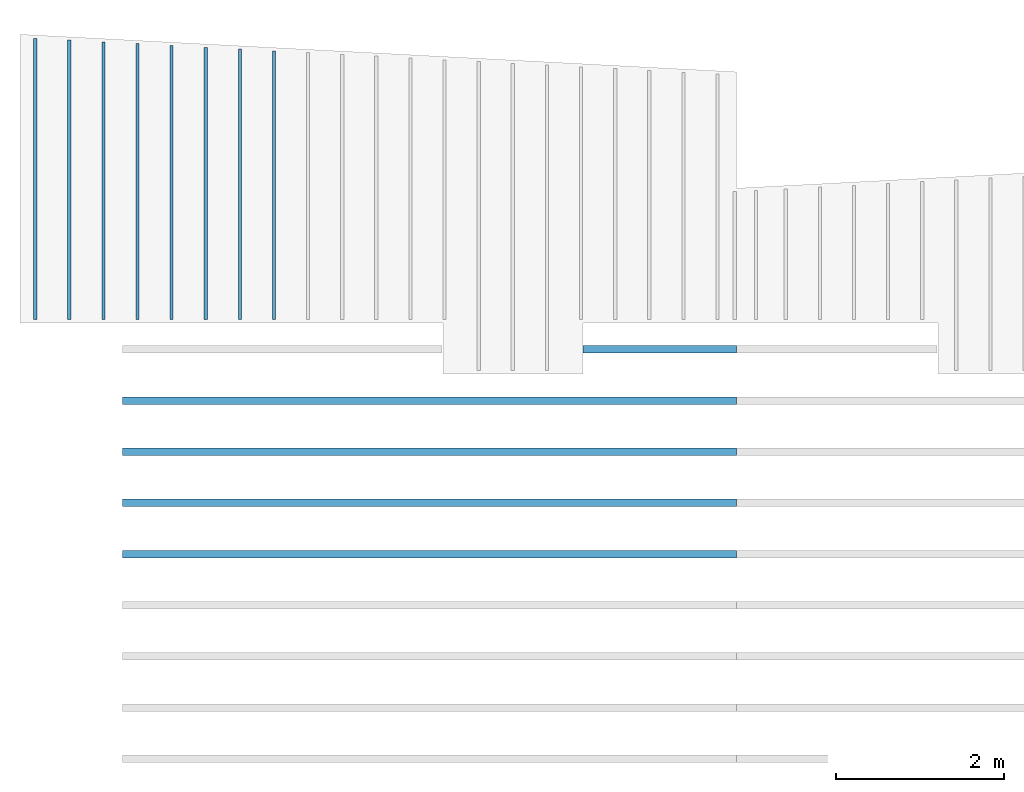
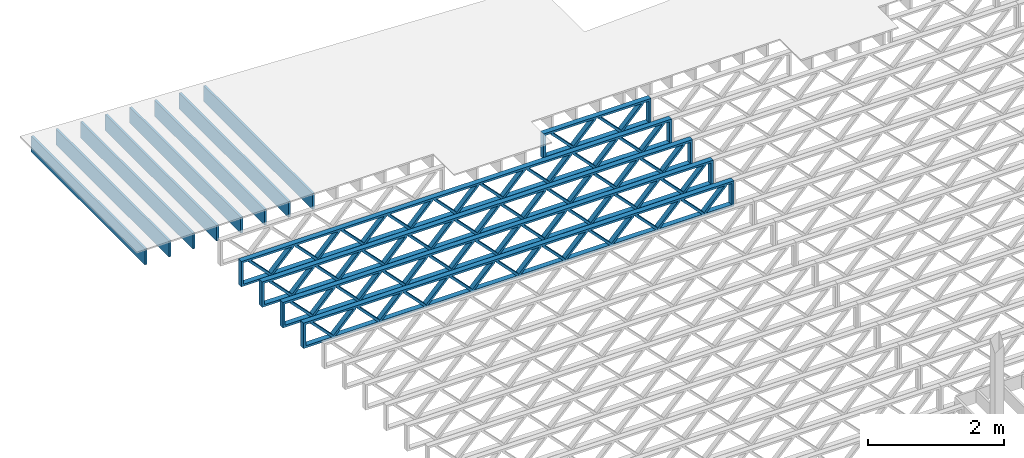
# One storey, part 3 of 13: 13 beams, 2 elements without a shape of their own.
"""IFC4 building model written with IfcOpenShell, lengths in feet."""

import ifcopenshell
import ifcopenshell.guid

model = None  # the IFC model being written
_history = None  # IfcOwnerHistory: only IFC2X3 demands one
_inside = {}  # id of a spatial element -> (the spatial element, [elements in it])
_under = {}  # id of a project, library or spatial element -> (it, [spatial elements below it])
_declared = {}  # id of a project -> (the project, [libraries it declares])
_typed = {}  # id of a type object -> (the type object, [elements of that type])
_made_of = {}  # id of a material, layer set ... -> (it, [elements and type objects made of it])


def new_model(schema):
    """Start an empty IFC model of exactly this schema.

    Asked for "IFC4X3", IfcOpenShell would pick the latest addendum, in which some entities
    have other attributes; the version numbers below select the first issue.
    IFC2X3 requires an IfcOwnerHistory on every rooted entity: one is made here for all.
    """
    global model, _history
    if schema == "IFC4X3":
        model = ifcopenshell.file(schema_version=(4, 3, 0, 0))
    else:
        model = ifcopenshell.file(schema=schema)
    _inside.clear()
    _under.clear()
    _declared.clear()
    _typed.clear()
    _made_of.clear()
    _history = None
    if model.schema == "IFC2X3":
        org = make("IfcOrganization", Name="unknown")
        user = make(
            "IfcPersonAndOrganization",
            ThePerson=make("IfcPerson", FamilyName="unknown"),
            TheOrganization=org,
        )
        app = make(
            "IfcApplication",
            ApplicationDeveloper=org,
            Version="unknown",
            ApplicationFullName="unknown",
            ApplicationIdentifier="unknown",
        )
        _history = make(
            "IfcOwnerHistory",
            OwningUser=user,
            OwningApplication=app,
            ChangeAction="ADDED",
            CreationDate=0,
        )
    return model


def make(cls, **values):
    """One entity of the class cls with the attributes given. An attribute that is None is left unset."""
    return model.create_entity(
        cls, **{name: value for name, value in values.items() if value is not None}
    )


def entity(cls, *values):
    """Any entity or typed value of the class cls, its attributes in the order of the schema. None: left unset."""
    e = model.create_entity(cls)
    for i, value in enumerate(values):
        if value is not None:
            e[i] = value
    return e


def rooted(cls, **values):
    """An entity with a GlobalId (a new one), such as an element, a storey or a relation."""
    return make(cls, GlobalId=ifcopenshell.guid.new(), OwnerHistory=_history, **values)


def si_unit(unit_type, name, prefix=None):
    """IfcSIUnit, for example si_unit("LENGTHUNIT", "METRE", prefix="MILLI")."""
    return make("IfcSIUnit", UnitType=unit_type, Prefix=prefix, Name=name)


def converted_unit(unit_type, name, factor, base, dimensions=None, offset=None):
    """IfcConversionBasedUnit, such as the inch: factor (a typed value) times the base unit."""
    return make(
        "IfcConversionBasedUnit"
        if offset is None
        else "IfcConversionBasedUnitWithOffset",
        ConversionOffset=offset,
        Dimensions=None
        if dimensions is None
        else entity("IfcDimensionalExponents", *dimensions),
        UnitType=unit_type,
        Name=name,
        ConversionFactor=make(
            "IfcMeasureWithUnit", ValueComponent=factor, UnitComponent=base
        ),
    )


def derived_unit(unit_type, elements):
    """IfcDerivedUnit: a product of units, each with its exponent."""
    return make(
        "IfcDerivedUnit",
        Elements=[
            make("IfcDerivedUnitElement", Unit=unit, Exponent=power)
            for unit, power in elements
        ],
        UnitType=unit_type,
    )


def assignment(units):
    """IfcUnitAssignment: the units of a project."""
    return None if units is None else make("IfcUnitAssignment", Units=units)


def point(xyz):
    """IfcCartesianPoint."""
    return None if xyz is None else make("IfcCartesianPoint", Coordinates=xyz)


def direction(xyz):
    """IfcDirection."""
    return None if xyz is None else make("IfcDirection", DirectionRatios=xyz)


def frame(location, z_axis=None, x_axis=None):
    """IfcAxis2Placement3D, a coordinate frame: its origin and axes. An axis left out is left unset."""
    return make(
        "IfcAxis2Placement3D",
        Location=point(location),
        Axis=direction(z_axis),
        RefDirection=direction(x_axis),
    )


def frame_2d(location, x_axis=None):
    """IfcAxis2Placement2D, a coordinate frame in the plane: its origin and x axis."""
    return make(
        "IfcAxis2Placement2D", Location=point(location), RefDirection=direction(x_axis)
    )


def origin():
    """The frame at (0, 0, 0) with its axes left unset."""
    return frame((0.0, 0.0, 0.0))


def origin_2d_with_axis():
    """The frame at (0, 0) in the plane with the x axis (1, 0) written out."""
    return frame_2d((0.0, 0.0), x_axis=(1.0, 0.0))


def place(relative_to, where):
    """IfcLocalPlacement: puts the frame where relative to a parent placement (None: the world)."""
    return make(
        "IfcLocalPlacement", PlacementRelTo=relative_to, RelativePlacement=where
    )


def context(
    kind, dimensions, precision=None, world=None, true_north=None, identifier=None
):
    """IfcGeometricRepresentationContext, for example the 3D "Model" context."""
    return make(
        "IfcGeometricRepresentationContext",
        ContextIdentifier=identifier,
        ContextType=kind,
        CoordinateSpaceDimension=dimensions,
        Precision=precision,
        WorldCoordinateSystem=world,
        TrueNorth=true_north,
    )


def subcontext(parent, identifier, kind, view, scale=None):
    """IfcGeometricRepresentationSubContext, for example "Body" below "Model"."""
    return make(
        "IfcGeometricRepresentationSubContext",
        ContextIdentifier=identifier,
        ContextType=kind,
        ParentContext=parent,
        TargetScale=scale,
        TargetView=view,
    )


def project(units=None, contexts=None):
    """IfcProject with its units and contexts."""
    return rooted(
        "IfcProject",
        Name="project",
        RepresentationContexts=contexts,
        UnitsInContext=assignment(units),
    )


def spatial(cls, under=None, at=None, **own):
    """A site, building, storey or space (cls), placed at a placement, below another one or the project."""
    s = rooted(cls, ObjectPlacement=at, **own)
    if under is not None:
        _under.setdefault(under.id(), (under, []))[1].append(s)
    return s


def profile(cls, at=None, kind="AREA", **sizes):
    """A parametric profile (cls). Its sizes go by their IFC names, for example OverallWidth=200.0."""
    return make(cls, ProfileType=kind, Position=at, **sizes)


def rectangle(**sizes):
    """IfcRectangleProfileDef."""
    return profile("IfcRectangleProfileDef", **sizes)


def extrude(swept, where, along, depth):
    """IfcExtrudedAreaSolid: the profile swept, set in the frame where, extruded along a direction by depth."""
    return make(
        "IfcExtrudedAreaSolid",
        SweptArea=swept,
        Position=where,
        ExtrudedDirection=direction(along),
        Depth=depth,
    )


def shape(context_of_items, identifier, shape_type, items):
    """IfcShapeRepresentation: the items that make up one representation, for example the "Body"."""
    return make(
        "IfcShapeRepresentation",
        ContextOfItems=context_of_items,
        RepresentationIdentifier=identifier,
        RepresentationType=shape_type,
        Items=items,
    )


def source(mapping_origin, context_of_items, identifier, shape_type, items):
    """IfcRepresentationMap: a shape defined once, which mapped items show again and again."""
    return make(
        "IfcRepresentationMap",
        MappingOrigin=mapping_origin,
        MappedRepresentation=shape(context_of_items, identifier, shape_type, items),
    )


def transform(
    local_origin,
    x_axis=None,
    y_axis=None,
    z_axis=None,
    scale=None,
    scale2=None,
    scale3=None,
    uniform=True,
):
    """IfcCartesianTransformationOperator3D, or its non-uniform kind. x_axis, y_axis, z_axis: its Axis1, 2, 3."""
    if uniform:
        return make(
            "IfcCartesianTransformationOperator3D",
            Axis1=direction(x_axis),
            Axis2=direction(y_axis),
            LocalOrigin=point(local_origin),
            Scale=scale,
            Axis3=direction(z_axis),
        )
    return make(
        "IfcCartesianTransformationOperator3DnonUniform",
        Axis1=direction(x_axis),
        Axis2=direction(y_axis),
        LocalOrigin=point(local_origin),
        Scale=scale,
        Axis3=direction(z_axis),
        Scale2=scale2,
        Scale3=scale3,
    )


def mapped(mapping_source, mapping_target):
    """IfcMappedItem: shows the shape of a source again, moved by a transform."""
    return make(
        "IfcMappedItem", MappingSource=mapping_source, MappingTarget=mapping_target
    )


def material(Name=None, Category=None):
    """IfcMaterial."""
    return make("IfcMaterial", Name=Name, Category=Category)


def material_profile(
    of_material, cross_section, Name=None, Category=None, Priority=None
):
    """IfcMaterialProfile: a cross section and its material."""
    return make(
        "IfcMaterialProfile",
        Name=Name,
        Material=of_material,
        Profile=cross_section,
        Priority=Priority,
        Category=Category,
    )


def profile_set(profiles, Name=None, composite=None):
    """IfcMaterialProfileSet."""
    return make(
        "IfcMaterialProfileSet",
        Name=Name,
        MaterialProfiles=profiles,
        CompositeProfile=composite,
    )


def profile_usage(for_profile_set, cardinal=None, extent=None):
    """IfcMaterialProfileSetUsage: how a profile set lies along its element."""
    return make(
        "IfcMaterialProfileSetUsage",
        ForProfileSet=for_profile_set,
        CardinalPoint=cardinal,
        ReferenceExtent=extent,
    )


def made_of(thing, what):
    """Note that an element or type object is made of a material, layer set ...; save() writes the relation."""
    if what is not None:
        _made_of.setdefault(what.id(), (what, []))[1].append(thing)
    return thing


def type_object(cls, material=None, **own):
    """A type object (cls), such as IfcWallType, which elements share."""
    return made_of(rooted(cls, **own), material)


def type_shapes(of_type, sources):
    """Give a type object the sources (RepresentationMaps) that its elements show as mapped items."""
    of_type.RepresentationMaps = sources


def element(
    cls,
    number,
    at=None,
    inside=None,
    cuts=None,
    type_object=None,
    material=None,
    context=None,
    identifier="Body",
    shape_type=None,
    held_by="IfcProductDefinitionShape",
    body=None,
    shapes=None,
    **own,
):
    """One element of the class cls, such as IfcWall. Its Tag is "e" and its number.

    at: its placement. inside: the storey or other place that contains it. cuts: it is an
    opening in that element (IfcRelVoidsElement). A single representation is given by context,
    identifier, shape_type and body (its items); several are given by shapes. held_by: the class
    of the entity that holds the representations. save() writes the other relations.
    """
    e = rooted(cls, Tag="e%d" % number, ObjectPlacement=at, **own)
    if body is not None:
        shapes = [shape(context, identifier, shape_type, body)]
    if shapes is not None:
        e.Representation = make(held_by, Representations=shapes)
    if inside is not None:
        _inside.setdefault(inside.id(), (inside, []))[1].append(e)
    if cuts is not None:
        rooted(
            "IfcRelVoidsElement", RelatingBuildingElement=cuts, RelatedOpeningElement=e
        )
    if type_object is not None:
        _typed.setdefault(type_object.id(), (type_object, []))[1].append(e)
    return made_of(e, material)


def aggregate(whole, parts):
    """IfcRelAggregates: a whole, such as a stair, and the parts it consists of."""
    return rooted("IfcRelAggregates", RelatingObject=whole, RelatedObjects=parts)


def save(model, path):
    """Write the relations noted so far, then the file.

    IfcRelAggregates (storeys below a building ...), IfcRelContainedInSpatialStructure (elements
    in a storey), IfcRelDefinesByType, IfcRelAssociatesMaterial and IfcRelDeclares: one each for
    every whole, place, type object, material and project.
    """
    for whole, parts in _under.values():
        aggregate(whole, parts)
    for where, things in _inside.values():
        rooted(
            "IfcRelContainedInSpatialStructure",
            RelatedElements=things,
            RelatingStructure=where,
        )
    for kind, things in _typed.values():
        rooted("IfcRelDefinesByType", RelatedObjects=things, RelatingType=kind)
    for what, things in _made_of.values():
        rooted("IfcRelAssociatesMaterial", RelatedObjects=things, RelatingMaterial=what)
    for by, libraries in _declared.values():
        rooted("IfcRelDeclares", RelatingContext=by, RelatedDefinitions=libraries)
    model.write(path)


model = new_model("IFC4")

# Units and contexts
model_context_1 = context("Model", 3, precision=0.0001, world=origin(), true_north=direction((6.12303176911189e-17, 1.0)))
model_context_2 = context("Model", 3, precision=0.0001, world=origin(), true_north=direction((6.12303176911189e-17, 1.0)))
body_context = subcontext(model_context_2, "Body", "Model", "MODEL_VIEW")
ifc_project = project(units=[converted_unit("LENGTHUNIT", "FOOT", entity("IfcRatioMeasure", 0.3048), si_unit("LENGTHUNIT", "METRE"), dimensions=[1, 0, 0, 0, 0, 0, 0]), converted_unit("AREAUNIT", "SQUARE FOOT", entity("IfcRatioMeasure", 0.09290304), si_unit("AREAUNIT", "SQUARE_METRE"), dimensions=[2, 0, 0, 0, 0, 0, 0]), converted_unit("VOLUMEUNIT", "CUBIC FOOT", entity("IfcRatioMeasure", 0.028316846592), si_unit("VOLUMEUNIT", "CUBIC_METRE"), dimensions=[3, 0, 0, 0, 0, 0, 0]), converted_unit("PLANEANGLEUNIT", "DEGREE", entity("IfcRatioMeasure", 0.0174532925199433), si_unit("PLANEANGLEUNIT", "RADIAN"), dimensions=[0, 0, 0, 0, 0, 0, 0]), si_unit("MASSUNIT", "GRAM", prefix="KILO"), derived_unit("MASSDENSITYUNIT", [(si_unit("MASSUNIT", "GRAM", prefix="KILO"), 1), (si_unit("LENGTHUNIT", "METRE"), -3)]), derived_unit("MOMENTOFINERTIAUNIT", [(si_unit("LENGTHUNIT", "METRE"), 4)]), si_unit("TIMEUNIT", "SECOND"), si_unit("FREQUENCYUNIT", "HERTZ"), si_unit("THERMODYNAMICTEMPERATUREUNIT", "DEGREE_CELSIUS"), derived_unit("THERMALTRANSMITTANCEUNIT", [(si_unit("MASSUNIT", "GRAM", prefix="KILO"), 1), (si_unit("THERMODYNAMICTEMPERATUREUNIT", "KELVIN"), -1), (si_unit("TIMEUNIT", "SECOND"), -3)]), derived_unit("VOLUMETRICFLOWRATEUNIT", [(si_unit("LENGTHUNIT", "METRE"), 3), (si_unit("TIMEUNIT", "SECOND"), -1)]), si_unit("ELECTRICCURRENTUNIT", "AMPERE"), si_unit("ELECTRICVOLTAGEUNIT", "VOLT"), si_unit("POWERUNIT", "WATT"), si_unit("FORCEUNIT", "NEWTON"), si_unit("ILLUMINANCEUNIT", "LUX"), si_unit("LUMINOUSFLUXUNIT", "LUMEN"), si_unit("LUMINOUSINTENSITYUNIT", "CANDELA"), derived_unit("USERDEFINED", [(si_unit("MASSUNIT", "GRAM", prefix="KILO"), -1), (si_unit("LENGTHUNIT", "METRE"), -2), (si_unit("TIMEUNIT", "SECOND"), 3), (si_unit("LUMINOUSFLUXUNIT", "LUMEN"), 1)]), derived_unit("LINEARVELOCITYUNIT", [(si_unit("LENGTHUNIT", "METRE"), 1), (si_unit("TIMEUNIT", "SECOND"), -1)]), si_unit("PRESSUREUNIT", "PASCAL"), derived_unit("USERDEFINED", [(si_unit("LENGTHUNIT", "METRE"), -2), (si_unit("MASSUNIT", "GRAM", prefix="KILO"), 1), (si_unit("TIMEUNIT", "SECOND"), -2)]), derived_unit("LINEARFORCEUNIT", [(si_unit("MASSUNIT", "GRAM", prefix="KILO"), 1), (si_unit("LENGTHUNIT", "METRE"), 1), (si_unit("TIMEUNIT", "SECOND"), -2), (si_unit("LENGTHUNIT", "METRE"), -1)]), derived_unit("PLANARFORCEUNIT", [(si_unit("MASSUNIT", "GRAM", prefix="KILO"), 1), (si_unit("LENGTHUNIT", "METRE"), 1), (si_unit("TIMEUNIT", "SECOND"), -2), (si_unit("LENGTHUNIT", "METRE"), -2)])], contexts=[model_context_1])

# Site, building, storey
site_placement = place(None, origin())
site = spatial("IfcSite", under=ifc_project, at=site_placement, CompositionType="ELEMENT")
building_placement = place(site_placement, origin())
building = spatial("IfcBuilding", under=site, at=building_placement, CompositionType="ELEMENT")
storey_placement = place(building_placement, frame((0.0, 0.0, 21.46875)))
storey = spatial("IfcBuildingStorey", under=building, at=storey_placement, Name="3RD FLOOR", CompositionType="ELEMENT", Elevation=21.46875)

# Assembly, beams
assembly_1_placement = place(storey_placement, origin())
assembly_1 = element("IfcElementAssembly", 1, at=assembly_1_placement, inside=storey, Name="Structural Beam System:Structural Framing System", ObjectType="Structural Beam System:Structural Framing System", AssemblyPlace="NOTDEFINED", PredefinedType="BEAM_GRID")
ifc_material_1 = material(Category="Materials")
ifc_material_profile_1 = material_profile(ifc_material_1, rectangle(XDim=0.9375, YDim=0.125000000000011, at=origin_2d_with_axis()))
ifc_profile_set_1 = profile_set([ifc_material_profile_1])
ifc_profile_usage_1 = profile_usage(ifc_profile_set_1, cardinal=8)
beam_type_1 = type_object("IfcBeamType", PredefinedType="BEAM", material=ifc_profile_set_1)
shared_shape_1 = source(origin(), body_context, "Body", "SweptSolid", [
    extrude(rectangle(XDim=0.9375, YDim=0.125000000000011, at=origin_2d_with_axis()), frame((-5.2509000693218, 0.0, 0.0), z_axis=(1.0, 0.0, 0.0), x_axis=(0.0, 0.0, -1.0)), (0.0, 0.0, 1.0), 10.5018001386436),
])
type_shapes(beam_type_1, [shared_shape_1])
beam_1_placement = place(assembly_1_placement, frame((-259.810956052701, 964.279501138386, -0.729166666666714), z_axis=(0.0, 0.0, 1.0), x_axis=(0.0, 1.0, 0.0)))
beam_1 = element("IfcBeam", 2, at=beam_1_placement, type_object=beam_type_1, material=ifc_profile_usage_1, PredefinedType="BEAM", context=body_context, shape_type="MappedRepresentation", body=[
    mapped(shared_shape_1, transform((0.0, 0.0, 0.0), scale=1.0)),
])
ifc_profile_usage_2 = profile_usage(ifc_profile_set_1, cardinal=8)
beam_type_2 = type_object("IfcBeamType", PredefinedType="BEAM", material=ifc_profile_set_1)
shared_shape_2 = source(origin(), body_context, "Body", "SweptSolid", [
    extrude(rectangle(XDim=0.9375, YDim=0.125000000000011, at=origin_2d_with_axis()), frame((-5.32077710836586, 0.0, 0.0), z_axis=(1.0, 0.0, 0.0), x_axis=(0.0, 0.0, -1.0)), (0.0, 0.0, 1.0), 10.6415542167317),
])
type_shapes(beam_type_2, [shared_shape_2])
beam_2_placement = place(assembly_1_placement, frame((-262.477622719368, 964.34937817743, -0.729166666666714), z_axis=(0.0, 0.0, 1.0), x_axis=(0.0, 1.0, 0.0)))
beam_2 = element("IfcBeam", 3, at=beam_2_placement, type_object=beam_type_2, material=ifc_profile_usage_2, PredefinedType="BEAM", context=body_context, shape_type="MappedRepresentation", body=[
    mapped(shared_shape_2, transform((0.0, 0.0, 0.0), scale=1.0)),
])
ifc_profile_usage_3 = profile_usage(ifc_profile_set_1, cardinal=8)
beam_type_3 = type_object("IfcBeamType", PredefinedType="BEAM", material=ifc_profile_set_1)
shared_shape_3 = source(origin(), body_context, "Body", "SweptSolid", [
    extrude(rectangle(XDim=0.9375, YDim=0.125000000000011, at=origin_2d_with_axis()), frame((-5.39065414740986, 0.0, 0.0), z_axis=(1.0, 0.0, 0.0), x_axis=(0.0, 0.0, -1.0)), (0.0, 0.0, 1.0), 10.7813082948197),
])
type_shapes(beam_type_3, [shared_shape_3])
beam_3_placement = place(assembly_1_placement, frame((-265.144289386034, 964.419255216474, -0.729166666666714), z_axis=(0.0, 0.0, 1.0), x_axis=(0.0, 1.0, 0.0)))
beam_3 = element("IfcBeam", 4, at=beam_3_placement, type_object=beam_type_3, material=ifc_profile_usage_3, PredefinedType="BEAM", context=body_context, shape_type="MappedRepresentation", body=[
    mapped(shared_shape_3, transform((0.0, 0.0, 0.0), scale=1.0)),
])
ifc_profile_usage_4 = profile_usage(ifc_profile_set_1, cardinal=8)
beam_type_4 = type_object("IfcBeamType", PredefinedType="BEAM", material=ifc_profile_set_1)
shared_shape_4 = source(origin(), body_context, "Body", "SweptSolid", [
    extrude(rectangle(XDim=0.9375, YDim=0.125000000000011, at=origin_2d_with_axis()), frame((-5.49546970597595, 0.0, 0.0), z_axis=(1.0, 0.0, 0.0), x_axis=(0.0, 0.0, -1.0)), (0.0, 0.0, 1.0), 10.9909394119519),
])
type_shapes(beam_type_4, [shared_shape_4])
beam_4_placement = place(assembly_1_placement, frame((-269.144289386034, 964.52407077504, -0.729166666666714), z_axis=(0.0, 0.0, 1.0), x_axis=(0.0, 1.0, 0.0)))
beam_4 = element("IfcBeam", 5, at=beam_4_placement, type_object=beam_type_4, material=ifc_profile_usage_4, PredefinedType="BEAM", context=body_context, shape_type="MappedRepresentation", body=[
    mapped(shared_shape_4, transform((0.0, 0.0, 0.0), scale=1.0)),
])
ifc_profile_usage_5 = profile_usage(ifc_profile_set_1, cardinal=8)
beam_type_5 = type_object("IfcBeamType", PredefinedType="BEAM", material=ifc_profile_set_1)
shared_shape_5 = source(origin(), body_context, "Body", "SweptSolid", [
    extrude(rectangle(XDim=0.9375, YDim=0.125000000000011, at=origin_2d_with_axis()), frame((-5.46053118645392, 0.0, 0.0), z_axis=(1.0, 0.0, 0.0), x_axis=(0.0, 0.0, -1.0)), (0.0, 0.0, 1.0), 10.9210623729078),
])
type_shapes(beam_type_5, [shared_shape_5])
beam_5_placement = place(assembly_1_placement, frame((-267.810956052701, 964.489132255518, -0.729166666666714), z_axis=(0.0, 0.0, 1.0), x_axis=(0.0, 1.0, 0.0)))
beam_5 = element("IfcBeam", 6, at=beam_5_placement, type_object=beam_type_5, material=ifc_profile_usage_5, PredefinedType="BEAM", context=body_context, shape_type="MappedRepresentation", body=[
    mapped(shared_shape_5, transform((0.0, 0.0, 0.0), scale=1.0)),
])
ifc_profile_usage_6 = profile_usage(ifc_profile_set_1, cardinal=8)
beam_type_6 = type_object("IfcBeamType", PredefinedType="BEAM", material=ifc_profile_set_1)
shared_shape_6 = source(origin(), body_context, "Body", "SweptSolid", [
    extrude(rectangle(XDim=0.9375, YDim=0.125000000000011, at=origin_2d_with_axis()), frame((-5.42559266693189, 0.0, 0.0), z_axis=(1.0, 0.0, 0.0), x_axis=(0.0, 0.0, -1.0)), (0.0, 0.0, 1.0), 10.8511853338638),
])
type_shapes(beam_type_6, [shared_shape_6])
beam_6_placement = place(assembly_1_placement, frame((-266.477622719368, 964.454193735996, -0.729166666666714), z_axis=(0.0, 0.0, 1.0), x_axis=(0.0, 1.0, 0.0)))
beam_6 = element("IfcBeam", 7, at=beam_6_placement, type_object=beam_type_6, material=ifc_profile_usage_6, PredefinedType="BEAM", context=body_context, shape_type="MappedRepresentation", body=[
    mapped(shared_shape_6, transform((0.0, 0.0, 0.0), scale=1.0)),
])
ifc_profile_usage_7 = profile_usage(ifc_profile_set_1, cardinal=8)
beam_type_7 = type_object("IfcBeamType", PredefinedType="BEAM", material=ifc_profile_set_1)
shared_shape_7 = source(origin(), body_context, "Body", "SweptSolid", [
    extrude(rectangle(XDim=0.9375, YDim=0.125000000000011, at=origin_2d_with_axis()), frame((-5.35571562788789, 0.0, 0.0), z_axis=(1.0, 0.0, 0.0), x_axis=(0.0, 0.0, -1.0)), (0.0, 0.0, 1.0), 10.7114312557758),
])
type_shapes(beam_type_7, [shared_shape_7])
beam_7_placement = place(assembly_1_placement, frame((-263.810956052701, 964.384316696952, -0.729166666666714), z_axis=(0.0, 0.0, 1.0), x_axis=(0.0, 1.0, 0.0)))
beam_7 = element("IfcBeam", 8, at=beam_7_placement, type_object=beam_type_7, material=ifc_profile_usage_7, PredefinedType="BEAM", context=body_context, shape_type="MappedRepresentation", body=[
    mapped(shared_shape_7, transform((0.0, 0.0, 0.0), scale=1.0)),
])
ifc_profile_usage_8 = profile_usage(ifc_profile_set_1, cardinal=8)
beam_type_8 = type_object("IfcBeamType", PredefinedType="BEAM", material=ifc_profile_set_1)
shared_shape_8 = source(origin(), body_context, "Body", "SweptSolid", [
    extrude(rectangle(XDim=0.9375, YDim=0.125000000000011, at=origin_2d_with_axis()), frame((-5.28583858884383, 0.0, 0.0), z_axis=(1.0, 0.0, 0.0), x_axis=(0.0, 0.0, -1.0)), (0.0, 0.0, 1.0), 10.5716771776877),
])
type_shapes(beam_type_8, [shared_shape_8])
beam_8_placement = place(assembly_1_placement, frame((-261.144289386034, 964.314439657908, -0.729166666666714), z_axis=(0.0, 0.0, 1.0), x_axis=(0.0, 1.0, 0.0)))
beam_8 = element("IfcBeam", 9, at=beam_8_placement, type_object=beam_type_8, material=ifc_profile_usage_8, PredefinedType="BEAM", context=body_context, shape_type="MappedRepresentation", body=[
    mapped(shared_shape_8, transform((0.0, 0.0, 0.0), scale=1.0)),
])
aggregate(assembly_1, [beam_1, beam_2, beam_3, beam_4, beam_5, beam_6, beam_7, beam_8])

assembly_2_placement = place(storey_placement, origin())
assembly_2 = element("IfcElementAssembly", 10, at=assembly_2_placement, inside=storey, Name="Structural Beam System:Structural Framing System", ObjectType="Structural Beam System:Structural Framing System", AssemblyPlace="NOTDEFINED", PredefinedType="BEAM_GRID")
ifc_material_2 = material(Name="WOOD TRUSS", Category="Materials")
ifc_material_profile_2 = material_profile(ifc_material_2, rectangle(XDim=1.73473973950632, YDim=0.125, at=frame_2d((-1.11022302462516e-16, 8.32667268468867e-17), x_axis=(1.0, 0.0))))
ifc_material_profile_3 = material_profile(ifc_material_2, rectangle(XDim=1.73473973950633, YDim=0.125, at=frame_2d((-1.11022302462516e-16, 8.32667268468867e-17), x_axis=(1.0, 0.0))))
ifc_material_profile_4 = material_profile(ifc_material_2, rectangle(XDim=1.73473973950632, YDim=0.125, at=frame_2d((-5.55111512312578e-17, 1.38777878078145e-16), x_axis=(1.0, 0.0))))
ifc_material_profile_5 = material_profile(ifc_material_2, rectangle(XDim=1.73473973950633, YDim=0.125, at=frame_2d((-1.11022302462516e-16, 8.32667268468867e-17), x_axis=(1.0, 0.0))))
ifc_material_profile_6 = material_profile(ifc_material_2, rectangle(XDim=1.73473973950632, YDim=0.125, at=frame_2d((-1.11022302462516e-16, 8.32667268468867e-17), x_axis=(1.0, 0.0))))
ifc_material_profile_7 = material_profile(ifc_material_2, rectangle(XDim=1.73473973950633, YDim=0.125, at=frame_2d((-2.77555756156289e-16, 3.05311331771918e-16), x_axis=(1.0, 0.0))))
ifc_material_profile_8 = material_profile(ifc_material_2, rectangle(XDim=1.73473973950632, YDim=0.124999999999999, at=frame_2d((-3.88578058618805e-16, -2.4980018054066e-16), x_axis=(1.0, 0.0))))
ifc_material_profile_9 = material_profile(ifc_material_2, rectangle(XDim=1.73473973950633, YDim=0.125, at=frame_2d((2.77555756156289e-16, -3.05311331771918e-16), x_axis=(1.0, 0.0))))
ifc_material_profile_10 = material_profile(ifc_material_2, rectangle(XDim=1.73473973950632, YDim=0.124999999999999, at=frame_2d((-1.11022302462516e-16, 8.32667268468867e-17), x_axis=(1.0, 0.0))))
ifc_material_profile_11 = material_profile(ifc_material_2, rectangle(XDim=1.73473973950633, YDim=0.125, at=origin_2d_with_axis()))
ifc_material_profile_12 = material_profile(ifc_material_2, rectangle(XDim=0.124999999999982, YDim=0.291666666666668, at=origin_2d_with_axis()))
ifc_material_profile_13 = material_profile(ifc_material_2, rectangle(XDim=0.124999999999932, YDim=0.291666666666664, at=origin_2d_with_axis()))
ifc_material_profile_14 = material_profile(ifc_material_2, rectangle(XDim=1.25000000000002, YDim=0.29166666666667, at=origin_2d_with_axis()))
ifc_material_profile_15 = material_profile(ifc_material_2, rectangle(XDim=1.25000000000004, YDim=0.291666666666667, at=origin_2d_with_axis()))
ifc_profile_set_2 = profile_set([ifc_material_profile_2, ifc_material_profile_3, ifc_material_profile_4, ifc_material_profile_5, ifc_material_profile_6, ifc_material_profile_7, ifc_material_profile_8, ifc_material_profile_9, ifc_material_profile_10, ifc_material_profile_11, ifc_material_profile_12, ifc_material_profile_13, ifc_material_profile_14, ifc_material_profile_15])
ifc_profile_usage_9 = profile_usage(ifc_profile_set_2, cardinal=8)
beam_type_9 = type_object("IfcBeamType", PredefinedType="BEAM", material=ifc_profile_set_2)
shared_shape_9 = source(origin(), body_context, "Body", "SweptSolid", [
    extrude(rectangle(XDim=1.73473973950632, YDim=0.124999999999999, at=frame_2d((5.55111512312578e-16, 7.21644966006352e-16), x_axis=(1.0, 0.0))), frame((8.37514585578398, -0.145833333333334, 0.0), z_axis=(0.0, 1.0, 0.0), x_axis=(0.693383046997606, 0.0, 0.720569184836762)), (0.0, 0.0, 1.0), 0.291666666666667),
    extrude(rectangle(XDim=1.73473973950633, YDim=0.125, at=origin_2d_with_axis()), frame((7.12485998211071, -0.145833333333334, 0.0), z_axis=(0.0, 1.0, 0.0), x_axis=(0.69338304699761, 0.0, -0.720569184836758)), (0.0, 0.0, 1.0), 0.291666666666666),
    extrude(rectangle(XDim=1.73473973950632, YDim=0.124999999999999, at=frame_2d((-1.11022302462516e-16, 8.32667268468867e-17), x_axis=(1.0, 0.0))), frame((5.79181154946831, -0.145833333333334, 0.0), z_axis=(0.0, 1.0, 0.0), x_axis=(0.693383046997606, 0.0, 0.720569184836762)), (0.0, 0.0, 1.0), 0.291666666666667),
    extrude(rectangle(XDim=1.73473973950633, YDim=0.125, at=origin_2d_with_axis()), frame((4.54152567579504, -0.145833333333334, 0.0), z_axis=(0.0, 1.0, 0.0), x_axis=(0.69338304699761, 0.0, -0.720569184836758)), (0.0, 0.0, 1.0), 0.291666666666666),
    extrude(rectangle(XDim=1.73473973950632, YDim=0.125, at=frame_2d((2.22044604925031e-16, 3.88578058618805e-16), x_axis=(1.0, 0.0))), frame((3.20847724315264, -0.145833333333334, 0.0), z_axis=(0.0, 1.0, 0.0), x_axis=(0.693383046997606, 0.0, 0.720569184836762)), (0.0, 0.0, 1.0), 0.291666666666667),
    extrude(rectangle(XDim=1.73473973950633, YDim=0.125, at=frame_2d((-1.11022302462516e-16, 8.32667268468867e-17), x_axis=(1.0, 0.0))), frame((1.95819136947937, -0.145833333333334, 0.0), z_axis=(0.0, 1.0, 0.0), x_axis=(0.69338304699761, 0.0, -0.720569184836758)), (0.0, 0.0, 1.0), 0.291666666666667),
    extrude(rectangle(XDim=1.73473973950632, YDim=0.125, at=frame_2d((-5.55111512312578e-17, 1.38777878078145e-16), x_axis=(1.0, 0.0))), frame((0.625142936836964, -0.145833333333334, 0.0), z_axis=(0.0, 1.0, 0.0), x_axis=(0.693383046997606, 0.0, 0.720569184836762)), (0.0, 0.0, 1.0), 0.291666666666667),
    extrude(rectangle(XDim=1.73473973950633, YDim=0.125, at=frame_2d((-1.11022302462516e-16, 8.32667268468867e-17), x_axis=(1.0, 0.0))), frame((-0.625142936836306, -0.145833333333334, 0.0), z_axis=(0.0, 1.0, 0.0), x_axis=(0.69338304699761, 0.0, -0.720569184836758)), (0.0, 0.0, 1.0), 0.291666666666667),
    extrude(rectangle(XDim=1.73473973950632, YDim=0.125, at=frame_2d((-1.11022302462516e-16, 8.32667268468867e-17), x_axis=(1.0, 0.0))), frame((-1.95819136947871, -0.145833333333334, 0.0), z_axis=(0.0, 1.0, 0.0), x_axis=(0.693383046997606, 0.0, 0.720569184836762)), (0.0, 0.0, 1.0), 0.291666666666667),
    extrude(rectangle(XDim=1.73473973950633, YDim=0.125, at=origin_2d_with_axis()), frame((-3.20847724315198, -0.145833333333334, 0.0), z_axis=(0.0, 1.0, 0.0), x_axis=(0.69338304699761, 0.0, -0.720569184836758)), (0.0, 0.0, 1.0), 0.291666666666667),
    extrude(rectangle(XDim=1.73473973950632, YDim=0.124999999999999, at=frame_2d((-1.11022302462516e-16, 8.32667268468867e-17), x_axis=(1.0, 0.0))), frame((-4.54152567579438, -0.145833333333334, 0.0), z_axis=(0.0, 1.0, 0.0), x_axis=(0.693383046997606, 0.0, 0.720569184836762)), (0.0, 0.0, 1.0), 0.291666666666667),
    extrude(rectangle(XDim=1.73473973950633, YDim=0.125, at=origin_2d_with_axis()), frame((-5.79181154946765, -0.145833333333334, 0.0), z_axis=(0.0, 1.0, 0.0), x_axis=(0.69338304699761, 0.0, -0.720569184836758)), (0.0, 0.0, 1.0), 0.291666666666666),
    extrude(rectangle(XDim=1.73473973950632, YDim=0.124999999999999, at=frame_2d((-1.11022302462516e-16, 8.32667268468867e-17), x_axis=(1.0, 0.0))), frame((-7.12485998211005, -0.145833333333334, 0.0), z_axis=(0.0, 1.0, 0.0), x_axis=(0.693383046997606, 0.0, 0.720569184836762)), (0.0, 0.0, 1.0), 0.291666666666667),
    extrude(rectangle(XDim=1.73473973950633, YDim=0.125, at=frame_2d((-2.77555756156289e-16, 3.05311331771918e-16), x_axis=(1.0, 0.0))), frame((-8.37514585578332, -0.145833333333334, 0.0), z_axis=(0.0, 1.0, 0.0), x_axis=(0.69338304699761, 0.0, -0.720569184836758)), (0.0, 0.0, 1.0), 0.291666666666666),
    extrude(rectangle(XDim=1.73473973950632, YDim=0.125, at=frame_2d((-7.21644966006352e-16, -5.55111512312578e-16), x_axis=(1.0, 0.0))), frame((10.9584801620997, -0.145833333333334, 0.0), z_axis=(0.0, 1.0, 0.0), x_axis=(0.693383046997606, 0.0, 0.720569184836762)), (0.0, 0.0, 1.0), 0.291666666666667),
    extrude(rectangle(XDim=1.73473973950633, YDim=0.125, at=origin_2d_with_axis()), frame((9.70819428842638, -0.145833333333334, 0.0), z_axis=(0.0, 1.0, 0.0), x_axis=(0.69338304699761, 0.0, -0.720569184836758)), (0.0, 0.0, 1.0), 0.291666666666666),
    extrude(rectangle(XDim=1.73473973950632, YDim=0.125, at=frame_2d((-5.55111512312578e-17, 8.32667268468867e-17), x_axis=(1.0, 0.0))), frame((-9.70819428842572, -0.145833333333334, 0.0), z_axis=(0.0, 1.0, 0.0), x_axis=(0.693383046997606, 0.0, 0.720569184836762)), (0.0, 0.0, 1.0), 0.291666666666667),
    extrude(rectangle(XDim=1.73473973950633, YDim=0.125, at=origin_2d_with_axis()), frame((-10.958480162099, -0.145833333333334, 0.0), z_axis=(0.0, 1.0, 0.0), x_axis=(0.69338304699761, 0.0, -0.720569184836758)), (0.0, 0.0, 1.0), 0.291666666666666),
    extrude(rectangle(XDim=0.124999999999982, YDim=0.291666666666668, at=origin_2d_with_axis()), frame((-12.0000038919293, 0.0, 0.687500000000054), z_axis=(1.0, 0.0, 0.0), x_axis=(0.0, 0.0, -1.0)), (0.0, 0.0, 1.0), 24.0000077838585),
    extrude(rectangle(XDim=0.124999999999932, YDim=0.291666666666664, at=origin_2d_with_axis()), frame((-12.0000038919291, 0.0, -0.687499999999984), z_axis=(1.0, 0.0, 0.0), x_axis=(0.0, 0.0, -1.0)), (0.0, 0.0, 1.0), 24.0000077838583),
    extrude(rectangle(XDim=1.25000000000002, YDim=0.29166666666667, at=origin_2d_with_axis()), frame((11.8750038919292, 0.0, 0.0), z_axis=(1.0, 0.0, 0.0), x_axis=(0.0, 0.0, -1.0)), (0.0, 0.0, 1.0), 0.12500000000002),
    extrude(rectangle(XDim=1.25000000000004, YDim=0.291666666666667, at=origin_2d_with_axis()), frame((-12.0000038919293, 0.0, 0.0), z_axis=(1.0, 0.0, 0.0), x_axis=(0.0, 0.0, -1.0)), (0.0, 0.0, 1.0), 0.125000000000023),
])
type_shapes(beam_type_9, [shared_shape_9])
beam_9_placement = place(assembly_2_placement, frame((-253.738164405664, 949.861934882651, -0.947916666657857)))
beam_9 = element("IfcBeam", 11, at=beam_9_placement, type_object=beam_type_9, material=ifc_profile_usage_9, PredefinedType="BEAM", context=body_context, shape_type="MappedRepresentation", body=[
    mapped(shared_shape_9, transform((0.0, 0.0, 0.0), scale=1.0)),
])
ifc_profile_usage_10 = profile_usage(ifc_profile_set_2, cardinal=8)
beam_10_placement = place(assembly_2_placement, frame((-253.738164405664, 951.861934882651, -0.947916666657857)))
beam_10 = element("IfcBeam", 12, at=beam_10_placement, type_object=beam_type_9, material=ifc_profile_usage_10, PredefinedType="BEAM", context=body_context, shape_type="MappedRepresentation", body=[
    mapped(shared_shape_9, transform((0.0, 0.0, 0.0), scale=1.0)),
])
ifc_profile_usage_11 = profile_usage(ifc_profile_set_2, cardinal=8)
beam_11_placement = place(assembly_2_placement, frame((-253.738164405664, 953.861934882651, -0.947916666657857)))
beam_11 = element("IfcBeam", 13, at=beam_11_placement, type_object=beam_type_9, material=ifc_profile_usage_11, PredefinedType="BEAM", context=body_context, shape_type="MappedRepresentation", body=[
    mapped(shared_shape_9, transform((0.0, 0.0, 0.0), scale=1.0)),
])
ifc_profile_usage_12 = profile_usage(ifc_profile_set_2, cardinal=8)
beam_type_10 = type_object("IfcBeamType", PredefinedType="BEAM", material=ifc_profile_set_2)
shared_shape_10 = source(origin(), body_context, "Body", "SweptSolid", [
    extrude(rectangle(XDim=1.73473973950632, YDim=0.124999999999999, at=frame_2d((5.55111512312578e-16, 7.21644966006352e-16), x_axis=(1.0, 0.0))), frame((8.37514585578398, -0.145833333333334, 0.0), z_axis=(0.0, 1.0, 0.0), x_axis=(0.693383046997606, 0.0, 0.720569184836762)), (0.0, 0.0, 1.0), 0.291666666666667),
    extrude(rectangle(XDim=1.73473973950633, YDim=0.125, at=origin_2d_with_axis()), frame((7.12485998211071, -0.145833333333334, 0.0), z_axis=(0.0, 1.0, 0.0), x_axis=(0.69338304699761, 0.0, -0.720569184836758)), (0.0, 0.0, 1.0), 0.291666666666666),
    extrude(rectangle(XDim=1.73473973950632, YDim=0.124999999999999, at=frame_2d((-1.11022302462516e-16, 8.32667268468867e-17), x_axis=(1.0, 0.0))), frame((5.79181154946831, -0.145833333333334, 0.0), z_axis=(0.0, 1.0, 0.0), x_axis=(0.693383046997606, 0.0, 0.720569184836762)), (0.0, 0.0, 1.0), 0.291666666666667),
    extrude(rectangle(XDim=1.73473973950633, YDim=0.125, at=origin_2d_with_axis()), frame((4.54152567579504, -0.145833333333334, 0.0), z_axis=(0.0, 1.0, 0.0), x_axis=(0.69338304699761, 0.0, -0.720569184836758)), (0.0, 0.0, 1.0), 0.291666666666666),
    extrude(rectangle(XDim=1.73473973950632, YDim=0.125, at=frame_2d((2.22044604925031e-16, 3.88578058618805e-16), x_axis=(1.0, 0.0))), frame((3.20847724315264, -0.145833333333334, 0.0), z_axis=(0.0, 1.0, 0.0), x_axis=(0.693383046997606, 0.0, 0.720569184836762)), (0.0, 0.0, 1.0), 0.291666666666667),
    extrude(rectangle(XDim=1.73473973950633, YDim=0.125, at=frame_2d((-1.11022302462516e-16, 8.32667268468867e-17), x_axis=(1.0, 0.0))), frame((1.95819136947937, -0.145833333333334, 0.0), z_axis=(0.0, 1.0, 0.0), x_axis=(0.69338304699761, 0.0, -0.720569184836758)), (0.0, 0.0, 1.0), 0.291666666666667),
    extrude(rectangle(XDim=1.73473973950632, YDim=0.125, at=frame_2d((-5.55111512312578e-17, 1.38777878078145e-16), x_axis=(1.0, 0.0))), frame((0.625142936836964, -0.145833333333334, 0.0), z_axis=(0.0, 1.0, 0.0), x_axis=(0.693383046997606, 0.0, 0.720569184836762)), (0.0, 0.0, 1.0), 0.291666666666667),
    extrude(rectangle(XDim=1.73473973950633, YDim=0.125, at=frame_2d((-1.11022302462516e-16, 8.32667268468867e-17), x_axis=(1.0, 0.0))), frame((-0.625142936836306, -0.145833333333334, 0.0), z_axis=(0.0, 1.0, 0.0), x_axis=(0.69338304699761, 0.0, -0.720569184836758)), (0.0, 0.0, 1.0), 0.291666666666667),
    extrude(rectangle(XDim=1.73473973950632, YDim=0.125, at=frame_2d((-1.11022302462516e-16, 8.32667268468867e-17), x_axis=(1.0, 0.0))), frame((-1.95819136947871, -0.145833333333334, 0.0), z_axis=(0.0, 1.0, 0.0), x_axis=(0.693383046997606, 0.0, 0.720569184836762)), (0.0, 0.0, 1.0), 0.291666666666667),
    extrude(rectangle(XDim=1.73473973950633, YDim=0.125, at=origin_2d_with_axis()), frame((-3.20847724315198, -0.145833333333334, 0.0), z_axis=(0.0, 1.0, 0.0), x_axis=(0.69338304699761, 0.0, -0.720569184836758)), (0.0, 0.0, 1.0), 0.291666666666667),
    extrude(rectangle(XDim=1.73473973950632, YDim=0.124999999999999, at=frame_2d((-1.11022302462516e-16, 8.32667268468867e-17), x_axis=(1.0, 0.0))), frame((-4.54152567579438, -0.145833333333334, 0.0), z_axis=(0.0, 1.0, 0.0), x_axis=(0.693383046997606, 0.0, 0.720569184836762)), (0.0, 0.0, 1.0), 0.291666666666667),
    extrude(rectangle(XDim=1.73473973950633, YDim=0.125, at=origin_2d_with_axis()), frame((-5.79181154946765, -0.145833333333334, 0.0), z_axis=(0.0, 1.0, 0.0), x_axis=(0.69338304699761, 0.0, -0.720569184836758)), (0.0, 0.0, 1.0), 0.291666666666666),
    extrude(rectangle(XDim=1.73473973950632, YDim=0.124999999999999, at=frame_2d((-1.11022302462516e-16, 8.32667268468867e-17), x_axis=(1.0, 0.0))), frame((-7.12485998211005, -0.145833333333334, 0.0), z_axis=(0.0, 1.0, 0.0), x_axis=(0.693383046997606, 0.0, 0.720569184836762)), (0.0, 0.0, 1.0), 0.291666666666667),
    extrude(rectangle(XDim=1.73473973950633, YDim=0.125, at=frame_2d((-2.77555756156289e-16, 3.05311331771918e-16), x_axis=(1.0, 0.0))), frame((-8.37514585578332, -0.145833333333334, 0.0), z_axis=(0.0, 1.0, 0.0), x_axis=(0.69338304699761, 0.0, -0.720569184836758)), (0.0, 0.0, 1.0), 0.291666666666666),
    extrude(rectangle(XDim=1.73473973950632, YDim=0.125, at=frame_2d((-7.21644966006352e-16, -5.55111512312578e-16), x_axis=(1.0, 0.0))), frame((10.9584801620997, -0.145833333333334, 0.0), z_axis=(0.0, 1.0, 0.0), x_axis=(0.693383046997606, 0.0, 0.720569184836762)), (0.0, 0.0, 1.0), 0.291666666666667),
    extrude(rectangle(XDim=1.73473973950633, YDim=0.125, at=origin_2d_with_axis()), frame((9.70819428842638, -0.145833333333334, 0.0), z_axis=(0.0, 1.0, 0.0), x_axis=(0.69338304699761, 0.0, -0.720569184836758)), (0.0, 0.0, 1.0), 0.291666666666666),
    extrude(rectangle(XDim=1.73473973950632, YDim=0.125, at=frame_2d((-5.55111512312578e-17, 8.32667268468867e-17), x_axis=(1.0, 0.0))), frame((-9.70819428842572, -0.145833333333334, 0.0), z_axis=(0.0, 1.0, 0.0), x_axis=(0.693383046997606, 0.0, 0.720569184836762)), (0.0, 0.0, 1.0), 0.291666666666667),
    extrude(rectangle(XDim=1.73473973950633, YDim=0.125, at=origin_2d_with_axis()), frame((-10.958480162099, -0.145833333333334, 0.0), z_axis=(0.0, 1.0, 0.0), x_axis=(0.69338304699761, 0.0, -0.720569184836758)), (0.0, 0.0, 1.0), 0.291666666666666),
    extrude(rectangle(XDim=0.124999999999982, YDim=0.291666666666668, at=origin_2d_with_axis()), frame((-12.0000038919293, 0.0, 0.687500000000054), z_axis=(1.0, 0.0, 0.0), x_axis=(0.0, 0.0, -1.0)), (0.0, 0.0, 1.0), 24.0000077838585),
    extrude(rectangle(XDim=0.124999999999932, YDim=0.291666666666664, at=origin_2d_with_axis()), frame((-12.0000038919291, 0.0, -0.687499999999984), z_axis=(1.0, 0.0, 0.0), x_axis=(0.0, 0.0, -1.0)), (0.0, 0.0, 1.0), 24.0000077838583),
    extrude(rectangle(XDim=1.25000000000002, YDim=0.29166666666667, at=origin_2d_with_axis()), frame((11.8750038919292, 0.0, 0.0), z_axis=(1.0, 0.0, 0.0), x_axis=(0.0, 0.0, -1.0)), (0.0, 0.0, 1.0), 0.12500000000002),
    extrude(rectangle(XDim=1.25000000000004, YDim=0.291666666666667, at=origin_2d_with_axis()), frame((-12.0000038919293, 0.0, 0.0), z_axis=(1.0, 0.0, 0.0), x_axis=(0.0, 0.0, -1.0)), (0.0, 0.0, 1.0), 0.125000000000023),
])
type_shapes(beam_type_10, [shared_shape_10])
beam_12_placement = place(assembly_2_placement, frame((-253.738164405664, 955.861934882651, -0.947916666657857)))
beam_12 = element("IfcBeam", 14, at=beam_12_placement, type_object=beam_type_10, material=ifc_profile_usage_12, PredefinedType="BEAM", context=body_context, shape_type="MappedRepresentation", body=[
    mapped(shared_shape_10, transform((0.0, 0.0, 0.0), scale=1.0)),
])
ifc_profile_usage_13 = profile_usage(ifc_profile_set_2, cardinal=8)
beam_type_11 = type_object("IfcBeamType", PredefinedType="BEAM", material=ifc_profile_set_2)
shared_shape_11 = source(origin(), body_context, "Body", "SweptSolid", [
    extrude(rectangle(XDim=1.73473973950632, YDim=0.125, at=frame_2d((0.0, 1.66533453693773e-16), x_axis=(1.0, 0.0))), frame((1.95847576769603, -0.145833333333334, 0.0), z_axis=(0.0, 1.0, 0.0), x_axis=(0.693383046997606, 0.0, 0.720569184836762)), (0.0, 0.0, 1.0), 0.291666666666667),
    extrude(rectangle(XDim=1.73473973950633, YDim=0.125, at=frame_2d((-5.55111512312578e-17, 8.32667268468867e-17), x_axis=(1.0, 0.0))), frame((0.708189894022761, -0.145833333333334, 0.0), z_axis=(0.0, 1.0, 0.0), x_axis=(0.69338304699761, 0.0, -0.720569184836758)), (0.0, 0.0, 1.0), 0.291666666666667),
    extrude(rectangle(XDim=1.73473973950632, YDim=0.125, at=frame_2d((0.0, 1.66533453693773e-16), x_axis=(1.0, 0.0))), frame((-0.708189894022106, -0.145833333333334, 0.0), z_axis=(0.0, 1.0, 0.0), x_axis=(0.693383046997606, 0.0, 0.720569184836762)), (0.0, 0.0, 1.0), 0.291666666666667),
    extrude(rectangle(XDim=1.73473973950633, YDim=0.125, at=frame_2d((-2.22044604925031e-16, 2.22044604925031e-16), x_axis=(1.0, 0.0))), frame((-1.95847576769538, -0.145833333333334, 0.0), z_axis=(0.0, 1.0, 0.0), x_axis=(0.69338304699761, 0.0, -0.720569184836758)), (0.0, 0.0, 1.0), 0.291666666666666),
    extrude(rectangle(XDim=0.124999999999982, YDim=0.291666666666668, at=origin_2d_with_axis()), frame((-2.99999949752565, 0.0, 0.687500000000054), z_axis=(1.0, 0.0, 0.0), x_axis=(0.0, 0.0, -1.0)), (0.0, 0.0, 1.0), 5.9999989950513),
    extrude(rectangle(XDim=0.124999999999932, YDim=0.291666666666664, at=origin_2d_with_axis()), frame((-2.99999949752544, 0.0, -0.687499999999984), z_axis=(1.0, 0.0, 0.0), x_axis=(0.0, 0.0, -1.0)), (0.0, 0.0, 1.0), 5.99999899505109),
    extrude(rectangle(XDim=1.25000000000002, YDim=0.29166666666667, at=origin_2d_with_axis()), frame((2.87499949752563, 0.0, 0.0), z_axis=(1.0, 0.0, 0.0), x_axis=(0.0, 0.0, -1.0)), (0.0, 0.0, 1.0), 0.12500000000002),
    extrude(rectangle(XDim=1.25000000000004, YDim=0.291666666666667, at=origin_2d_with_axis()), frame((-2.99999949752565, 0.0, 0.0), z_axis=(1.0, 0.0, 0.0), x_axis=(0.0, 0.0, -1.0)), (0.0, 0.0, 1.0), 0.125000000000023),
])
type_shapes(beam_type_11, [shared_shape_11])
beam_13_placement = place(assembly_2_placement, frame((-244.738160011261, 957.861934882651, -0.947916666657846)))
beam_13 = element("IfcBeam", 15, at=beam_13_placement, type_object=beam_type_11, material=ifc_profile_usage_13, PredefinedType="BEAM", context=body_context, shape_type="MappedRepresentation", body=[
    mapped(shared_shape_11, transform((0.0, 0.0, 0.0), scale=1.0)),
])
aggregate(assembly_2, [beam_9, beam_10, beam_12, beam_13, beam_11])

save(model, "model.ifc")
